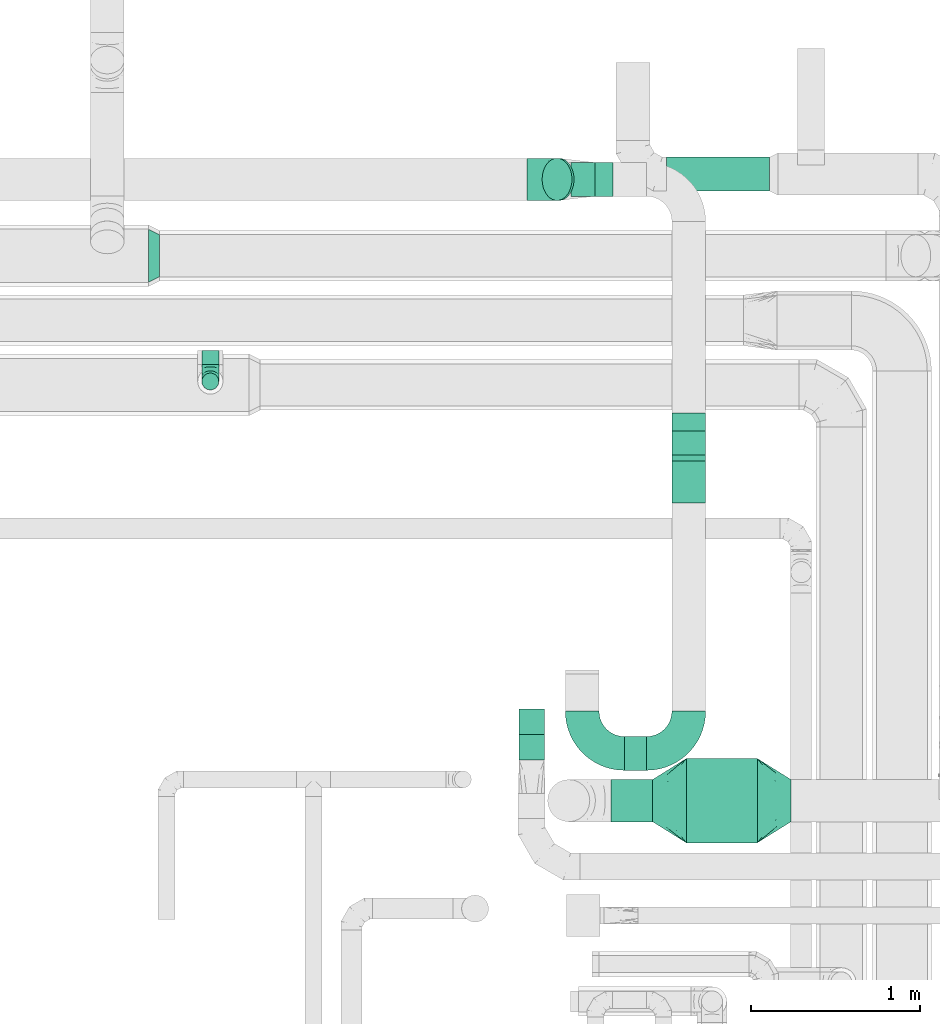
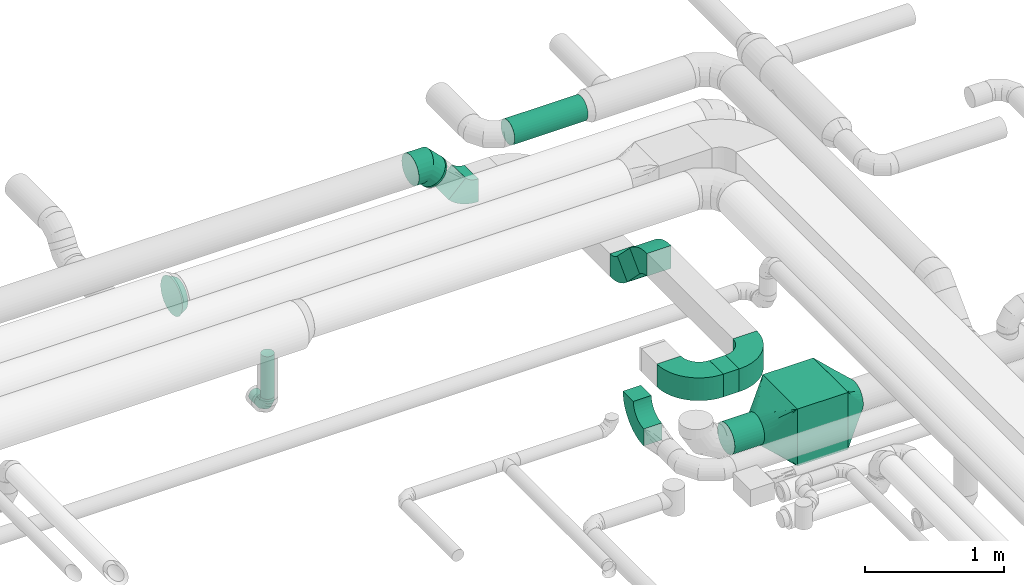
# One storey, part 71 of 92: 11 flow fittings, 8 flow segments.
"""IFC2X3 building model written with IfcOpenShell, lengths in millimetres."""

from ifc_helpers import new_model, entity, si_unit, converted_unit, derived_unit, direction, frame, frame_2d, origin, origin_2d_with_axis, place, context, subcontext, project, spatial, polyline, circle_curve, parameter, trimmed, segment, composite_curve, rectangle, circle, outline, extrude, faceted_brep, source, transform, mapped, material, type_object, type_shapes, element, save


model = new_model("IFC2X3")

# Units and contexts
model_context = context("Model", 3, precision=0.01, world=origin(), true_north=direction((6.12303176911189e-17, 1.0)))
body_context = subcontext(model_context, "Body", "Model", "MODEL_VIEW")
ifc_project = project(units=[si_unit("LENGTHUNIT", "METRE", prefix="MILLI"), si_unit("AREAUNIT", "SQUARE_METRE"), si_unit("VOLUMEUNIT", "CUBIC_METRE"), converted_unit("PLANEANGLEUNIT", "DEGREE", entity("IfcRatioMeasure", 0.0174532925199433), si_unit("PLANEANGLEUNIT", "RADIAN"), dimensions=[0, 0, 0, 0, 0, 0, 0]), si_unit("MASSUNIT", "GRAM", prefix="KILO"), derived_unit("MASSDENSITYUNIT", [(si_unit("MASSUNIT", "GRAM", prefix="KILO"), 1), (si_unit("LENGTHUNIT", "METRE"), -3)]), derived_unit("MOMENTOFINERTIAUNIT", [(si_unit("LENGTHUNIT", "METRE"), 4)]), si_unit("TIMEUNIT", "SECOND"), si_unit("FREQUENCYUNIT", "HERTZ"), si_unit("THERMODYNAMICTEMPERATUREUNIT", "DEGREE_CELSIUS"), derived_unit("THERMALTRANSMITTANCEUNIT", [(si_unit("MASSUNIT", "GRAM", prefix="KILO"), 1), (si_unit("THERMODYNAMICTEMPERATUREUNIT", "KELVIN"), -1), (si_unit("TIMEUNIT", "SECOND"), -3)]), derived_unit("VOLUMETRICFLOWRATEUNIT", [(si_unit("LENGTHUNIT", "METRE"), 3), (si_unit("TIMEUNIT", "SECOND"), -1)]), derived_unit("MASSFLOWRATEUNIT", [(si_unit("MASSUNIT", "GRAM", prefix="KILO"), 1), (si_unit("TIMEUNIT", "SECOND"), -1)]), derived_unit("ROTATIONALFREQUENCYUNIT", [(si_unit("TIMEUNIT", "SECOND"), -1)]), si_unit("ELECTRICCURRENTUNIT", "AMPERE"), si_unit("ELECTRICVOLTAGEUNIT", "VOLT"), si_unit("POWERUNIT", "WATT"), si_unit("FORCEUNIT", "NEWTON", prefix="KILO"), si_unit("ILLUMINANCEUNIT", "LUX"), si_unit("LUMINOUSFLUXUNIT", "LUMEN"), si_unit("LUMINOUSINTENSITYUNIT", "CANDELA"), derived_unit("USERDEFINED", [(si_unit("MASSUNIT", "GRAM", prefix="KILO"), -1), (si_unit("LENGTHUNIT", "METRE"), -2), (si_unit("TIMEUNIT", "SECOND"), 3), (si_unit("LUMINOUSFLUXUNIT", "LUMEN"), 1)]), derived_unit("LINEARVELOCITYUNIT", [(si_unit("LENGTHUNIT", "METRE"), 1), (si_unit("TIMEUNIT", "SECOND"), -1)]), si_unit("PRESSUREUNIT", "PASCAL"), derived_unit("USERDEFINED", [(si_unit("LENGTHUNIT", "METRE"), -2), (si_unit("MASSUNIT", "GRAM", prefix="KILO"), 1), (si_unit("TIMEUNIT", "SECOND"), -2)]), derived_unit("LINEARFORCEUNIT", [(si_unit("MASSUNIT", "GRAM", prefix="KILO"), 1), (si_unit("LENGTHUNIT", "METRE"), 1), (si_unit("TIMEUNIT", "SECOND"), -2), (si_unit("LENGTHUNIT", "METRE"), -1)]), derived_unit("PLANARFORCEUNIT", [(si_unit("MASSUNIT", "GRAM", prefix="KILO"), 1), (si_unit("LENGTHUNIT", "METRE"), 1), (si_unit("TIMEUNIT", "SECOND"), -2), (si_unit("LENGTHUNIT", "METRE"), -2)])], contexts=[model_context])

# Site, building, storey
site_placement = place(None, origin())
site = spatial("IfcSite", under=ifc_project, at=site_placement, CompositionType="ELEMENT")
building_placement = place(site_placement, origin())
building = spatial("IfcBuilding", under=site, at=building_placement, CompositionType="ELEMENT")
storey_placement = place(building_placement, frame((0.0, 0.0, 4200.0)))
storey = spatial("IfcBuildingStorey", under=building, at=storey_placement, CompositionType="ELEMENT", Elevation=4200.0)

# Flow segments
duct_segment_type_1 = type_object("IfcDuctSegmentType", PredefinedType="NOTDEFINED")
flow_segment_1_placement = place(storey_placement, frame((60167.28, 12243.72, 2750.0)))
element("IfcFlowSegment", 1, at=flow_segment_1_placement, inside=storey, type_object=duct_segment_type_1, context=body_context, shape_type="SweptSolid", body=[
    extrude(rectangle(XDim=420.0, YDim=500.000000000001, at=origin_2d_with_axis()), frame((210.0, 250.0, 0.0)), (0.0, 0.0, 1.0), 499.999999999999),
])
flow_segment_2_placement = place(storey_placement, frame((59799.99, 12673.45, 3224.59)))
element("IfcFlowSegment", 2, at=flow_segment_2_placement, inside=storey, type_object=duct_segment_type_1, context=body_context, shape_type="SweptSolid", body=[
    extrude(rectangle(XDim=131.571091925655, YDim=200.0, at=origin_2d_with_axis()), frame((65.79, 100.0, 0.0), z_axis=(0.0, 0.0, 1.0), x_axis=(-1.0, 0.0, 0.0)), (0.0, 0.0, 1.0), 200.0),
])
flow_segment_3_placement = place(storey_placement, frame((60081.56, 14363.57, 3002.51)))
element("IfcFlowSegment", 3, at=flow_segment_3_placement, inside=storey, type_object=duct_segment_type_1, context=body_context, shape_type="SweptSolid", body=[
    extrude(rectangle(XDim=200.000000000001, YDim=200.000000000007, at=frame_2d((0.0, 0.0), x_axis=(0.0, 1.0))), frame((100.0, 248.85, 70.71), z_axis=(0.0, -0.707106781186548, 0.707106781186548), x_axis=(1.0, 0.0, 0.0)), (0.0, 0.0, 1.0), 251.931610193159),
])
duct_segment_type_2 = type_object("IfcDuctSegmentType", PredefinedType="NOTDEFINED")
flow_segment_4_placement = place(storey_placement, frame((57295.37, 15077.0, 2548.4)))
element("IfcFlowSegment", 4, at=flow_segment_4_placement, inside=storey, type_object=duct_segment_type_2, context=body_context, shape_type="SweptSolid", body=[
    extrude(circle(Radius=50.0, at=origin_2d_with_axis()), frame((51.6, 0.0, 51.6), z_axis=(0.0, 1.0, 0.0), x_axis=(1.0, 0.0, 0.0)), (0.0, 0.0, 1.0), 84.9999999999027),
])
flow_segment_5_placement = place(storey_placement, frame((60050.74, 16104.62, 3218.4)))
element("IfcFlowSegment", 5, at=flow_segment_5_placement, inside=storey, type_object=duct_segment_type_2, context=body_context, shape_type="SweptSolid", body=[
    extrude(circle(Radius=100.0, at=origin_2d_with_axis()), frame((0.0, 101.6, 101.6), z_axis=(1.0, 0.0, 0.0), x_axis=(0.0, 1.0, 0.0)), (0.0, 0.0, 1.0), 609.257088554614),
])
flow_segment_6_placement = place(storey_placement, frame((57295.37, 14925.4, 2700.0)))
element("IfcFlowSegment", 6, at=flow_segment_6_placement, inside=storey, type_object=duct_segment_type_2, context=body_context, shape_type="SweptSolid", body=[
    extrude(circle(Radius=50.0, at=origin_2d_with_axis()), frame((51.6, 51.6, 0.0)), (0.0, 0.0, 1.0), 373.77500200031),
])
flow_segment_7_placement = place(storey_placement, frame((59311.06, 16047.89, 3124.66)))
element("IfcFlowSegment", 7, at=flow_segment_7_placement, inside=storey, type_object=duct_segment_type_2, context=body_context, shape_type="SweptSolid", body=[
    extrude(circle(Radius=125.0, at=origin_2d_with_axis()), frame((89.98, 126.6, 102.12), z_axis=(0.707106781186267, 0.0, -0.707106781186828), x_axis=(0.0, 1.0, 0.0)), (0.0, 0.0, 1.0), 17.1572875253657),
])
duct_segment_type_3 = type_object("IfcDuctSegmentType", PredefinedType="NOTDEFINED")
flow_segment_8_placement = place(storey_placement, frame((59719.99, 12367.12, 2873.4)))
element("IfcFlowSegment", 8, at=flow_segment_8_placement, inside=storey, type_object=duct_segment_type_3, context=body_context, shape_type="SweptSolid", body=[
    extrude(circle(Radius=125.0, at=origin_2d_with_axis()), frame((0.0, 126.6, 126.6), z_axis=(1.0, 0.0, 0.0), x_axis=(0.0, 1.0, 0.0)), (0.0, 0.0, 1.0), 247.290274497971),
])

# Flow fittings
ifc_material = material()
duct_fitting_type_1 = type_object("IfcDuctFittingType", PredefinedType="NOTDEFINED", material=ifc_material)
shared_shape_1 = source(origin(), body_context, "Body", "Brep", [
    faceted_brep([(-100.0, 0.0, -50.0), (-100.0, -12.94, -48.3), (-100.0, -25.0, -43.3), (-100.0, -35.36, -35.36), (-100.0, -43.3, -25.0), (-100.0, -48.3, -12.94), (-100.0, -50.0, 0.0), (-100.0, -48.3, 12.94), (-100.0, -43.3, 25.0), (-100.0, -35.36, 35.36), (-100.0, -25.0, 43.3), (-100.0, -12.94, 48.3), (-100.0, 0.0, 50.0), (-100.0, 12.94, 48.3), (-100.0, 25.0, 43.3), (-100.0, 35.36, 35.36), (-100.0, 43.3, 25.0), (-100.0, 48.3, 12.94), (-100.0, 50.0, 0.0), (-100.0, 48.3, -12.94), (-100.0, 43.3, -25.0), (-100.0, 35.36, -35.36), (-100.0, 25.0, -43.3), (-100.0, 12.94, -48.3), (-76.67, 12.94, 48.3), (-79.9, 25.0, 43.3), (-73.21, 0.0, 50.0), (-82.68, 35.36, 35.36), (-86.15, 48.3, 12.94), (-86.6, 50.0, 0.0), (-84.81, 43.3, 25.0), (-84.81, 43.3, -25.0), (-82.68, 35.36, -35.36), (-86.15, 48.3, -12.94), (-76.67, 12.94, -48.3), (-73.21, 0.0, -50.0), (-79.9, 25.0, -43.3), (-69.74, -12.94, -48.3), (-66.51, -25.0, -43.3), (-63.73, -35.36, -35.36), (-61.6, -43.3, -25.0), (-60.26, -48.3, -12.94), (-59.81, -50.0, 0.0), (-60.26, -48.3, 12.94), (-61.6, -43.3, 25.0), (-63.73, -35.36, 35.36), (-66.51, -25.0, 43.3), (-69.74, -12.94, 48.3), (-36.27, 36.27, 48.3), (-45.1, 45.1, 43.3), (-26.79, 26.79, 50.0), (-52.68, 52.68, 35.36), (-58.49, 58.49, 25.0), (-62.15, 62.15, 12.94), (-63.4, 63.4, 0.0), (-62.15, 62.15, -12.94), (-58.49, 58.49, -25.0), (-52.68, 52.68, -35.36), (-36.27, 36.27, -48.3), (-26.79, 26.79, -50.0), (-45.1, 45.1, -43.3), (-17.32, 17.32, -48.3), (-8.49, 8.49, -43.3), (-0.91, 0.91, -35.36), (4.9, -4.9, -25.0), (8.56, -8.56, -12.94), (9.81, -9.81, 0.0), (8.56, -8.56, 12.94), (4.9, -4.9, 25.0), (-0.91, 0.91, 35.36), (-8.49, 8.49, 43.3), (-17.32, 17.32, 48.3), (-12.94, 76.67, 48.3), (-25.0, 79.9, 43.3), (0.0, 73.21, 50.0), (-35.36, 82.68, 35.36), (-43.3, 84.81, 25.0), (-48.3, 86.15, 12.94), (-50.0, 86.6, 0.0), (-48.3, 86.15, -12.94), (-43.3, 84.81, -25.0), (-35.36, 82.68, -35.36), (-12.94, 76.67, -48.3), (0.0, 73.21, -50.0), (-25.0, 79.9, -43.3), (12.94, 69.74, -48.3), (25.0, 66.51, -43.3), (35.36, 63.73, -35.36), (43.3, 61.6, -25.0), (48.3, 60.26, -12.94), (50.0, 59.81, 0.0), (48.3, 60.26, 12.94), (43.3, 61.6, 25.0), (35.36, 63.73, 35.36), (25.0, 66.51, 43.3), (12.94, 69.74, 48.3), (-12.94, 100.0, -48.3), (-25.0, 100.0, -43.3), (-35.36, 100.0, -35.36), (-43.3, 100.0, -25.0), (-48.3, 100.0, -12.94), (-50.0, 100.0, 0.0), (-48.3, 100.0, 12.94), (-43.3, 100.0, 25.0), (-35.36, 100.0, 35.36), (-25.0, 100.0, 43.3), (-12.94, 100.0, 48.3), (0.0, 100.0, 50.0), (12.94, 100.0, 48.3), (25.0, 100.0, 43.3), (35.36, 100.0, 35.36), (43.3, 100.0, 25.0), (48.3, 100.0, 12.94), (50.0, 100.0, 0.0), (48.3, 100.0, -12.94), (43.3, 100.0, -25.0), (35.36, 100.0, -35.36), (25.0, 100.0, -43.3), (12.94, 100.0, -48.3), (0.0, 100.0, -50.0)], [[[0, 1, 2, 3, 4, 5, 6, 7, 8, 9, 10, 11, 12, 13, 14, 15, 16, 17, 18, 19, 20, 21, 22, 23]], [[24, 25, 14, 13]], [[26, 24, 13, 12]], [[14, 25, 27, 15]], [[28, 29, 18, 17]], [[30, 28, 17, 16]], [[15, 27, 30, 16]], [[20, 31, 32, 21]], [[33, 31, 20, 19]], [[18, 29, 33, 19]], [[34, 35, 0, 23]], [[36, 34, 23, 22]], [[32, 36, 22, 21]], [[2, 1, 37, 38]], [[3, 2, 38, 39]], [[0, 35, 37, 1]], [[5, 4, 40, 41]], [[6, 5, 41, 42]], [[3, 39, 40, 4]], [[6, 42, 43, 7]], [[7, 43, 44, 8]], [[8, 44, 45, 9]], [[10, 46, 47, 11]], [[11, 47, 26, 12]], [[10, 9, 45, 46]], [[48, 49, 25, 24]], [[50, 48, 24, 26]], [[27, 25, 49, 51]], [[52, 53, 28, 30]], [[51, 52, 30, 27]], [[29, 28, 53, 54]], [[55, 56, 31, 33]], [[54, 55, 33, 29]], [[57, 32, 31, 56]], [[58, 59, 35, 34]], [[60, 58, 34, 36]], [[57, 60, 36, 32]], [[37, 35, 59, 61]], [[38, 37, 61, 62]], [[39, 38, 62, 63]], [[41, 40, 64, 65]], [[42, 41, 65, 66]], [[63, 64, 40, 39]], [[43, 42, 66, 67]], [[44, 43, 67, 68]], [[68, 69, 45, 44]], [[46, 45, 69, 70]], [[47, 46, 70, 71]], [[26, 47, 71, 50]], [[72, 73, 49, 48]], [[74, 72, 48, 50]], [[51, 49, 73, 75]], [[76, 77, 53, 52]], [[75, 76, 52, 51]], [[54, 53, 77, 78]], [[79, 80, 56, 55]], [[78, 79, 55, 54]], [[81, 57, 56, 80]], [[82, 83, 59, 58]], [[84, 82, 58, 60]], [[81, 84, 60, 57]], [[61, 59, 83, 85]], [[62, 61, 85, 86]], [[63, 62, 86, 87]], [[65, 64, 88, 89]], [[66, 65, 89, 90]], [[87, 88, 64, 63]], [[67, 66, 90, 91]], [[68, 67, 91, 92]], [[92, 93, 69, 68]], [[70, 69, 93, 94]], [[71, 70, 94, 95]], [[50, 71, 95, 74]], [[96, 97, 98, 99, 100, 101, 102, 103, 104, 105, 106, 107, 108, 109, 110, 111, 112, 113, 114, 115, 116, 117, 118, 119]], [[72, 74, 107, 106]], [[73, 72, 106, 105]], [[75, 73, 105, 104]], [[77, 76, 103, 102]], [[78, 77, 102, 101]], [[75, 104, 103, 76]], [[78, 101, 100, 79]], [[79, 100, 99, 80]], [[80, 99, 98, 81]], [[96, 119, 83, 82]], [[97, 96, 82, 84]], [[84, 81, 98, 97]], [[83, 119, 118, 85]], [[85, 118, 117, 86]], [[86, 117, 116, 87]], [[88, 115, 114, 89]], [[89, 114, 113, 90]], [[87, 116, 115, 88]], [[91, 90, 113, 112]], [[92, 91, 112, 111]], [[93, 92, 111, 110]], [[95, 94, 109, 108]], [[74, 95, 108, 107]], [[110, 109, 94, 93]]]),
])
type_shapes(duct_fitting_type_1, [shared_shape_1])
flow_fitting_1_placement = place(storey_placement, frame((57346.97, 14977.0, 2600.0), z_axis=(1.0, 0.0, 0.0), x_axis=(0.0, 0.0, -1.0)))
element("IfcFlowFitting", 9, at=flow_fitting_1_placement, inside=storey, type_object=duct_fitting_type_1, material=ifc_material, context=body_context, shape_type="MappedRepresentation", body=[
    mapped(shared_shape_1, transform((0.0, 0.0, 0.0), scale=1.0)),
])
duct_fitting_type_2 = type_object("IfcDuctFittingType", PredefinedType="NOTDEFINED", material=ifc_material)
shared_shape_2 = source(origin(), body_context, "Body", "Brep", [
    faceted_brep([(200.0, 73.47, 101.13), (200.0, 56.05, 110.0), (200.0, 38.63, 118.88), (200.0, 23.84, 121.22), (200.0, 11.92, 123.11), (200.0, 5.96, 124.06), (200.0, 0.0, 125.0), (200.0, -5.96, 124.06), (200.0, -11.92, 123.11), (200.0, -23.84, 121.22), (200.0, -38.63, 118.88), (200.0, -56.05, 110.0), (200.0, -73.47, 101.13), (200.0, -87.3, 87.3), (200.0, -101.13, 73.47), (200.0, -110.0, 56.05), (200.0, -118.88, 38.63), (200.0, -121.22, 23.84), (200.0, -123.11, 11.92), (200.0, -124.06, 5.96), (200.0, -125.0, 0.0), (200.0, -124.06, -5.96), (200.0, -123.11, -11.92), (200.0, -121.22, -23.84), (200.0, -118.88, -38.63), (200.0, -110.0, -56.05), (200.0, -101.13, -73.47), (200.0, -87.3, -87.3), (200.0, -73.47, -101.13), (200.0, -56.05, -110.0), (200.0, -38.63, -118.88), (200.0, -23.84, -121.22), (200.0, -11.92, -123.11), (200.0, -5.96, -124.06), (200.0, 0.0, -125.0), (200.0, 5.96, -124.06), (200.0, 11.92, -123.11), (200.0, 23.84, -121.22), (200.0, 38.63, -118.88), (200.0, 56.05, -110.0), (200.0, 73.47, -101.13), (200.0, 87.3, -87.3), (200.0, 101.13, -73.47), (200.0, 110.0, -56.05), (200.0, 118.88, -38.63), (200.0, 121.22, -23.84), (200.0, 123.11, -11.92), (200.0, 124.06, -5.96), (200.0, 125.0, 0.0), (200.0, 124.06, 5.96), (200.0, 123.11, 11.92), (200.0, 121.22, 23.84), (200.0, 118.88, 38.63), (200.0, 110.0, 56.05), (200.0, 101.13, 73.47), (200.0, 87.3, 87.3), (0.0, -250.0, 250.0), (0.0, 250.0, 250.0), (0.0, 250.0, -250.0), (0.0, -250.0, -250.0), (104.11, -119.86, 184.93), (100.0, -166.44, 171.79), (26.03, -217.46, 233.73), (78.09, -152.39, 201.2), (52.06, -184.93, 217.46), (188.01, -14.98, 132.49), (176.03, -29.96, 139.98), (152.06, -59.93, 154.96), (128.09, -89.89, 169.95), (52.06, -217.46, 184.93), (78.09, -201.2, 152.39), (104.11, -184.93, 119.86), (128.09, -169.95, 89.89), (152.06, -154.96, 59.93), (176.03, -139.98, 29.96), (188.01, -132.49, 14.98), (26.03, -233.73, 217.46), (26.03, -233.73, -217.46), (52.06, -217.46, -184.93), (78.09, -201.2, -152.39), (104.11, -184.93, -119.86), (128.09, -169.95, -89.89), (152.06, -154.96, -59.93), (176.03, -139.98, -29.96), (188.01, -132.49, -14.98), (100.0, -171.79, -166.44), (52.06, -184.93, -217.46), (78.09, -152.39, -201.2), (104.11, -119.86, -184.93), (128.09, -89.89, -169.95), (152.06, -59.93, -154.96), (176.03, -29.96, -139.98), (188.01, -14.98, -132.49), (26.03, -217.46, -233.73), (26.03, 217.46, -233.73), (52.06, 184.93, -217.46), (78.09, 152.39, -201.2), (104.11, 119.86, -184.93), (128.09, 89.89, -169.95), (152.06, 59.93, -154.96), (176.03, 29.96, -139.98), (188.01, 14.98, -132.49), (100.0, 166.44, -171.79), (52.06, 217.46, -184.93), (78.09, 201.2, -152.39), (104.11, 184.93, -119.86), (128.09, 169.95, -89.89), (152.06, 154.96, -59.93), (176.03, 139.98, -29.96), (188.01, 132.49, -14.98), (26.03, 233.73, -217.46), (26.03, 233.73, 217.46), (52.06, 217.46, 184.93), (78.09, 201.2, 152.39), (104.11, 184.93, 119.86), (128.09, 169.95, 89.89), (152.06, 154.96, 59.93), (176.03, 139.98, 29.96), (188.01, 132.49, 14.98), (100.0, 171.79, 166.44), (52.06, 184.93, 217.46), (78.09, 152.39, 201.2), (104.11, 119.86, 184.93), (128.09, 89.89, 169.95), (152.06, 59.93, 154.96), (176.03, 29.96, 139.98), (188.01, 14.98, 132.49), (26.03, 217.46, 233.73)], [[[0, 1, 2, 3, 4, 5, 6, 7, 8, 9, 10, 11, 12, 13, 14, 15, 16, 17, 18, 19, 20, 21, 22, 23, 24, 25, 26, 27, 28, 29, 30, 31, 32, 33, 34, 35, 36, 37, 38, 39, 40, 41, 42, 43, 44, 45, 46, 47, 48, 49, 50, 51, 52, 53, 54, 55]], [[56, 57, 58, 59]], [[60, 11, 10]], [[56, 61, 62]], [[11, 60, 63, 64]], [[65, 66, 67, 68, 60, 10, 9, 8, 7, 6]], [[62, 61, 12]], [[15, 69, 70, 71]], [[64, 12, 11]], [[16, 71, 72, 73, 74, 75, 20, 19, 18, 17]], [[14, 76, 69]], [[71, 16, 15]], [[61, 76, 13]], [[12, 64, 62]], [[76, 14, 13]], [[12, 61, 13]], [[61, 56, 76]], [[69, 15, 14]], [[75, 74, 73, 72, 71, 70, 69, 76, 56, 59, 77, 78, 79, 80, 81, 82, 83, 84, 20]], [[80, 25, 24]], [[59, 85, 77]], [[25, 80, 79, 78]], [[84, 83, 82, 81, 80, 24, 23, 22, 21, 20]], [[77, 85, 26]], [[29, 86, 87, 88]], [[78, 26, 25]], [[30, 88, 89, 90, 91, 92, 34, 33, 32, 31]], [[28, 93, 86]], [[88, 30, 29]], [[85, 93, 27]], [[26, 78, 77]], [[93, 28, 27]], [[26, 85, 27]], [[85, 59, 93]], [[86, 29, 28]], [[92, 91, 90, 89, 88, 87, 86, 93, 59, 58, 94, 95, 96, 97, 98, 99, 100, 101, 34]], [[97, 39, 38]], [[58, 102, 94]], [[39, 97, 96, 95]], [[101, 100, 99, 98, 97, 38, 37, 36, 35, 34]], [[94, 102, 40]], [[43, 103, 104, 105]], [[95, 40, 39]], [[44, 105, 106, 107, 108, 109, 48, 47, 46, 45]], [[42, 110, 103]], [[105, 44, 43]], [[102, 110, 41]], [[40, 95, 94]], [[110, 42, 41]], [[40, 102, 41]], [[102, 58, 110]], [[103, 43, 42]], [[58, 57, 111, 112, 113, 114, 115, 116, 117, 118, 48, 109, 108, 107, 106, 105, 104, 103, 110]], [[114, 53, 52]], [[57, 119, 111]], [[53, 114, 113, 112]], [[118, 117, 116, 115, 114, 52, 51, 50, 49, 48]], [[111, 119, 54]], [[1, 120, 121, 122]], [[112, 54, 53]], [[2, 122, 123, 124, 125, 126, 6, 5, 4, 3]], [[0, 127, 120]], [[122, 2, 1]], [[119, 127, 55]], [[54, 112, 111]], [[127, 0, 55]], [[54, 119, 55]], [[119, 57, 127]], [[120, 1, 0]], [[57, 56, 62, 64, 63, 60, 68, 67, 66, 65, 6, 126, 125, 124, 123, 122, 121, 120, 127]]]),
])
type_shapes(duct_fitting_type_2, [shared_shape_2])
flow_fitting_2_placement = place(storey_placement, frame((60587.28, 12493.72, 3000.0)))
element("IfcFlowFitting", 10, at=flow_fitting_2_placement, inside=storey, type_object=duct_fitting_type_2, material=ifc_material, context=body_context, shape_type="MappedRepresentation", body=[
    mapped(shared_shape_2, transform((0.0, 0.0, 0.0), scale=1.0)),
])
flow_fitting_3_placement = place(storey_placement, frame((60167.28, 12493.72, 3000.0), z_axis=(0.0, 0.0, 1.0), x_axis=(-1.0, 0.0, 0.0)))
element("IfcFlowFitting", 11, at=flow_fitting_3_placement, inside=storey, type_object=duct_fitting_type_2, material=ifc_material, context=body_context, shape_type="MappedRepresentation", body=[
    mapped(shared_shape_2, transform((0.0, 0.0, 0.0), scale=1.0)),
])
duct_fitting_type_3 = type_object("IfcDuctFittingType", PredefinedType="NOTDEFINED", material=ifc_material)
shared_shape_3 = source(origin(), body_context, "Body", "Brep", [
    faceted_brep([(-103.55, 0.0, -125.0), (-103.55, -32.35, -120.74), (-103.55, -62.5, -108.25), (-103.55, -88.39, -88.39), (-103.55, -108.25, -62.5), (-103.55, -120.74, -32.35), (-103.55, -125.0, 0.0), (-103.55, -120.74, 32.35), (-103.55, -108.25, 62.5), (-103.55, -88.39, 88.39), (-103.55, -62.5, 108.25), (-103.55, -32.35, 120.74), (-103.55, 0.0, 125.0), (-103.55, 32.35, 120.74), (-103.55, 62.5, 108.25), (-103.55, 88.39, 88.39), (-103.55, 108.25, 62.5), (-103.55, 120.74, 32.35), (-103.55, 125.0, 0.0), (-103.55, 120.74, -32.35), (-103.55, 108.25, -62.5), (-103.55, 88.39, -88.39), (-103.55, 62.5, -108.25), (-103.55, 32.35, -120.74), (-13.4, 32.35, 120.74), (-25.89, 62.5, 108.25), (0.0, 0.0, 125.0), (-36.61, 88.39, 88.39), (-44.84, 108.25, 62.5), (-50.01, 120.74, 32.35), (-51.78, 125.0, 0.0), (-50.01, 120.74, -32.35), (-44.84, 108.25, -62.5), (-36.61, 88.39, -88.39), (-13.4, 32.35, -120.74), (0.0, 0.0, -125.0), (-25.89, 62.5, -108.25), (13.4, -32.35, -120.74), (25.89, -62.5, -108.25), (36.61, -88.39, -88.39), (44.84, -108.25, -62.5), (50.01, -120.74, -32.35), (51.78, -125.0, 0.0), (50.01, -120.74, 32.35), (44.84, -108.25, 62.5), (36.61, -88.39, 88.39), (25.89, -62.5, 108.25), (13.4, -32.35, 120.74), (73.22, 73.22, 125.0), (50.35, 96.1, 120.74), (29.03, 117.42, 108.25), (10.72, 135.72, 88.39), (-3.32, 149.77, 62.5), (-12.15, 158.6, 32.35), (-15.17, 161.61, 0.0), (-12.15, 158.6, -32.35), (-3.32, 149.77, -62.5), (10.72, 135.72, -88.39), (29.03, 117.42, -108.25), (50.35, 96.1, -120.74), (73.22, 73.22, -125.0), (96.1, 50.35, -120.74), (117.42, 29.03, -108.25), (135.72, 10.72, -88.39), (149.77, -3.32, -62.5), (158.6, -12.15, -32.35), (161.61, -15.17, 0.0), (158.6, -12.15, 32.35), (149.77, -3.32, 62.5), (135.72, 10.72, 88.39), (117.42, 29.03, 108.25), (96.1, 50.35, 120.74)], [[[0, 1, 2, 3, 4, 5, 6, 7, 8, 9, 10, 11, 12, 13, 14, 15, 16, 17, 18, 19, 20, 21, 22, 23]], [[24, 25, 14, 13]], [[26, 24, 13, 12]], [[14, 25, 27, 15]], [[28, 29, 17, 16]], [[28, 16, 15, 27]], [[30, 18, 17, 29]], [[31, 32, 20, 19]], [[30, 31, 19, 18]], [[32, 33, 21, 20]], [[34, 35, 0, 23]], [[36, 34, 23, 22]], [[33, 36, 22, 21]], [[1, 0, 35, 37]], [[2, 1, 37, 38]], [[38, 39, 3, 2]], [[5, 4, 40, 41]], [[6, 5, 41, 42]], [[39, 40, 4, 3]], [[6, 42, 43, 7]], [[7, 43, 44, 8]], [[8, 44, 45, 9]], [[9, 45, 46, 10]], [[10, 46, 47, 11]], [[26, 12, 11, 47]], [[24, 26, 48, 49]], [[25, 24, 49, 50]], [[27, 25, 50, 51]], [[29, 28, 52, 53]], [[30, 29, 53, 54]], [[51, 52, 28, 27]], [[30, 54, 55, 31]], [[31, 55, 56, 32]], [[57, 33, 32, 56]], [[36, 58, 59, 34]], [[34, 59, 60, 35]], [[58, 36, 33, 57]], [[35, 60, 61, 37]], [[37, 61, 62, 38]], [[63, 39, 38, 62]], [[40, 64, 65, 41]], [[41, 65, 66, 42]], [[64, 40, 39, 63]], [[43, 42, 66, 67]], [[44, 43, 67, 68]], [[68, 69, 45, 44]], [[47, 46, 70, 71]], [[26, 47, 71, 48]], [[69, 70, 46, 45]], [[59, 58, 57, 56, 55, 54, 53, 52, 51, 50, 49, 48, 71, 70, 69, 68, 67, 66, 65, 64, 63, 62, 61, 60]]]),
])
type_shapes(duct_fitting_type_3, [shared_shape_3])
flow_fitting_4_placement = place(storey_placement, frame((59327.82, 16174.48, 3300.0), z_axis=(0.0, -1.0, 0.0), x_axis=(-0.707106781186263, 0.0, 0.707106781186832)))
element("IfcFlowFitting", 12, at=flow_fitting_4_placement, inside=storey, type_object=duct_fitting_type_3, material=ifc_material, context=body_context, shape_type="MappedRepresentation", body=[
    mapped(shared_shape_3, transform((0.0, 0.0, 0.0), scale=1.0)),
])
duct_fitting_type_4 = type_object("IfcDuctFittingType", PredefinedType="NOTDEFINED", material=ifc_material)
shared_shape_4 = source(origin(), body_context, "Body", "Brep", [
    faceted_brep([(65.0, -78.75, -136.4), (65.0, -40.76, -152.13), (65.0, 0.0, -157.5), (65.0, 40.76, -152.13), (65.0, 78.75, -136.4), (65.0, 111.37, -111.37), (65.0, 136.4, -78.75), (65.0, 152.13, -40.76), (65.0, 157.5, 0.0), (65.0, 152.13, 40.76), (65.0, 136.4, 78.75), (65.0, 111.37, 111.37), (65.0, 78.75, 136.4), (65.0, 40.76, 152.13), (65.0, 0.0, 157.5), (65.0, -40.76, 152.13), (65.0, -78.75, 136.4), (65.0, -111.37, 111.37), (65.0, -136.4, 78.75), (65.0, -152.13, 40.76), (65.0, -157.5, 0.0), (65.0, -152.13, -40.76), (65.0, -136.4, -78.75), (65.0, -111.37, -111.37), (0.0, 38.63, -118.88), (0.0, 0.0, -125.0), (0.0, -38.63, -118.88), (0.0, -73.47, -101.13), (0.0, -101.13, -73.47), (0.0, -118.88, -38.63), (0.0, -125.0, 0.0), (0.0, -118.88, 38.63), (0.0, -101.13, 73.47), (0.0, -73.47, 101.13), (0.0, -38.63, 118.88), (0.0, 0.0, 125.0), (0.0, 38.63, 118.88), (0.0, 73.47, 101.13), (0.0, 101.13, 73.47), (0.0, 118.88, 38.63), (0.0, 125.0, 0.0), (0.0, 118.88, -38.63), (0.0, 101.13, -73.47), (0.0, 73.47, -101.13)], [[[0, 1, 2, 3, 4, 5, 6, 7, 8, 9, 10, 11, 12, 13, 14, 15, 16, 17, 18, 19, 20, 21, 22, 23]], [[24, 25, 26, 27, 28, 29, 30, 31, 32, 33, 34, 35, 36, 37, 38, 39, 40, 41, 42, 43]], [[39, 38, 10]], [[40, 39, 9]], [[40, 9, 8]], [[9, 39, 10]], [[38, 11, 10]], [[36, 35, 13]], [[37, 36, 12]], [[12, 11, 37]], [[13, 12, 36]], [[35, 14, 13]], [[37, 11, 38]], [[34, 33, 16]], [[35, 34, 15]], [[35, 15, 14]], [[15, 34, 16]], [[33, 17, 16]], [[31, 30, 19]], [[32, 31, 18]], [[18, 17, 32]], [[19, 18, 31]], [[30, 20, 19]], [[32, 17, 33]], [[29, 28, 22]], [[30, 29, 21]], [[30, 21, 20]], [[21, 29, 22]], [[28, 23, 22]], [[26, 25, 1]], [[27, 26, 0]], [[0, 23, 27]], [[1, 0, 26]], [[25, 2, 1]], [[27, 23, 28]], [[24, 43, 4]], [[25, 24, 3]], [[25, 3, 2]], [[3, 24, 4]], [[43, 5, 4]], [[41, 40, 7]], [[42, 41, 6]], [[6, 5, 42]], [[7, 6, 41]], [[40, 8, 7]], [[42, 5, 43]]]),
])
type_shapes(duct_fitting_type_4, [shared_shape_4])
flow_fitting_5_placement = place(storey_placement, frame((57045.65, 15722.0, 3250.0), z_axis=(0.0, 0.0, 1.0), x_axis=(-1.0, 0.0, 0.0)))
element("IfcFlowFitting", 13, at=flow_fitting_5_placement, inside=storey, type_object=duct_fitting_type_4, material=ifc_material, context=body_context, shape_type="MappedRepresentation", body=[
    mapped(shared_shape_4, transform((0.0, 0.0, 0.0), scale=1.0)),
])
duct_fitting_type_5 = type_object("IfcDuctFittingType", PredefinedType="NOTDEFINED", material=ifc_material)
shared_shape_5 = source(origin(), body_context, "Body", "SweptSolid", [
    extrude(outline(composite_curve([segment(polyline([(-187.5, -112.5), (-37.5, -112.5)]), True, "CONTINUOUS"), segment(trimmed(circle_curve(frame_2d((112.5, -112.5), x_axis=(0.0, 1.0)), 150.0), [parameter(0.0)], [parameter(90.0000000000001)], True, "PARAMETER"), False, "CONTINUOUS"), segment(polyline([(112.5, 37.5), (112.5, 187.5)]), True, "CONTINUOUS"), segment(trimmed(circle_curve(frame_2d((112.5, -112.5), x_axis=(0.0, 1.0)), 300.0), [parameter(0.0)], [parameter(90.0000000000001)], True, "PARAMETER"), True, "CONTINUOUS")], self_intersect=False)), frame((-112.5, 112.5, -75.0), z_axis=(0.0, 0.0, 1.0), x_axis=(-1.0, 0.0, 0.0)), (0.0, 0.0, 1.0), 150.0),
])
type_shapes(duct_fitting_type_5, [shared_shape_5])
flow_fitting_6_placement = place(storey_placement, frame((59251.13, 12960.58, 3050.0), z_axis=(1.0, 0.0, -1.83905089029899e-05), x_axis=(0.0, 1.0, 0.0)))
element("IfcFlowFitting", 14, at=flow_fitting_6_placement, inside=storey, type_object=duct_fitting_type_5, material=ifc_material, context=body_context, shape_type="MappedRepresentation", body=[
    mapped(shared_shape_5, transform((0.0, 0.0, 0.0), scale=1.0)),
])
duct_fitting_type_6 = type_object("IfcDuctFittingType", PredefinedType="NOTDEFINED", material=ifc_material)
shared_shape_6 = source(origin(), body_context, "Body", "SweptSolid", [
    extrude(outline(composite_curve([segment(polyline([(-225.0, -125.0), (-25.0, -125.0)]), True, "CONTINUOUS"), segment(trimmed(circle_curve(frame_2d((125.0, -125.0), x_axis=(0.0, 1.0)), 150.0), [parameter(0.0)], [parameter(90.0)], True, "PARAMETER"), False, "CONTINUOUS"), segment(polyline([(125.0, 25.0), (125.0, 225.0)]), True, "CONTINUOUS"), segment(trimmed(circle_curve(frame_2d((125.0, -125.0), x_axis=(0.0, 1.0)), 350.0), [parameter(0.0)], [parameter(90.0)], True, "PARAMETER"), True, "CONTINUOUS")], self_intersect=False)), frame((-125.0, 125.0, -100.0), z_axis=(0.0, 0.0, 1.0), x_axis=(-1.0, 0.0, 0.0)), (0.0, 0.0, 1.0), 200.0),
])
type_shapes(duct_fitting_type_6, [shared_shape_6])
flow_fitting_7_placement = place(storey_placement, frame((59549.99, 12773.45, 3324.59), z_axis=(0.0, 0.0, 1.0), x_axis=(0.0, -1.0, 0.0)))
element("IfcFlowFitting", 15, at=flow_fitting_7_placement, inside=storey, type_object=duct_fitting_type_6, material=ifc_material, context=body_context, shape_type="MappedRepresentation", body=[
    mapped(shared_shape_6, transform((0.0, 0.0, 0.0), scale=1.0)),
])
flow_fitting_8_placement = place(storey_placement, frame((60181.56, 12773.45, 3324.59)))
element("IfcFlowFitting", 16, at=flow_fitting_8_placement, inside=storey, type_object=duct_fitting_type_6, material=ifc_material, context=body_context, shape_type="MappedRepresentation", body=[
    mapped(shared_shape_6, transform((0.0, 0.0, 0.0), scale=1.0)),
])
duct_fitting_type_7 = type_object("IfcDuctFittingType", PredefinedType="NOTDEFINED", material=ifc_material)
shared_shape_7 = source(origin(), body_context, "Body", "SweptSolid", [
    extrude(outline(composite_curve([segment(polyline([(-136.61, -88.39), (63.39, -88.39)]), True, "CONTINUOUS"), segment(trimmed(circle_curve(frame_2d((213.39, -88.39), x_axis=(-0.707106781186546, 0.707106781186546)), 150.0), [parameter(0.0)], [parameter(45.0)], True, "PARAMETER"), False, "CONTINUOUS"), segment(polyline([(107.32, 17.68), (-34.1, 159.1)]), True, "CONTINUOUS"), segment(trimmed(circle_curve(frame_2d((213.39, -88.39), x_axis=(-0.707106781186546, 0.707106781186546)), 350.0), [parameter(0.0)], [parameter(45.0)], True, "PARAMETER"), True, "CONTINUOUS")], self_intersect=False)), frame((-15.17, 36.61, -100.0), z_axis=(0.0, 0.0, 1.0), x_axis=(-0.707106781186547, 0.707106781186548, 0.0)), (0.0, 0.0, 1.0), 200.0),
])
type_shapes(duct_fitting_type_7, [shared_shape_7])
for number, where, z_axis, x_axis in (
    (17, (60181.56, 14361.05, 3324.59), (-1.0, 0.0, 0.0), (0.0, 1.0, 0.0)),
    (18, (60181.56, 14685.64, 3000.0), (1.0, 0.0, 0.0), (0.0, 0.707106781186526, -0.707106781186569)),
    (19, (59627.82, 16174.48, 3000.0), (0.0, 1.0, 0.0), (-1.0, 0.0, 0.0)),
):
    element("IfcFlowFitting", number, at=place(storey_placement, frame(where, z_axis=z_axis, x_axis=x_axis)), inside=storey, type_object=duct_fitting_type_7, material=ifc_material, context=body_context, shape_type="MappedRepresentation", body=[
        mapped(shared_shape_7, transform((0.0, 0.0, 0.0), scale=1.0)),
    ])

save(model, "model.ifc")
